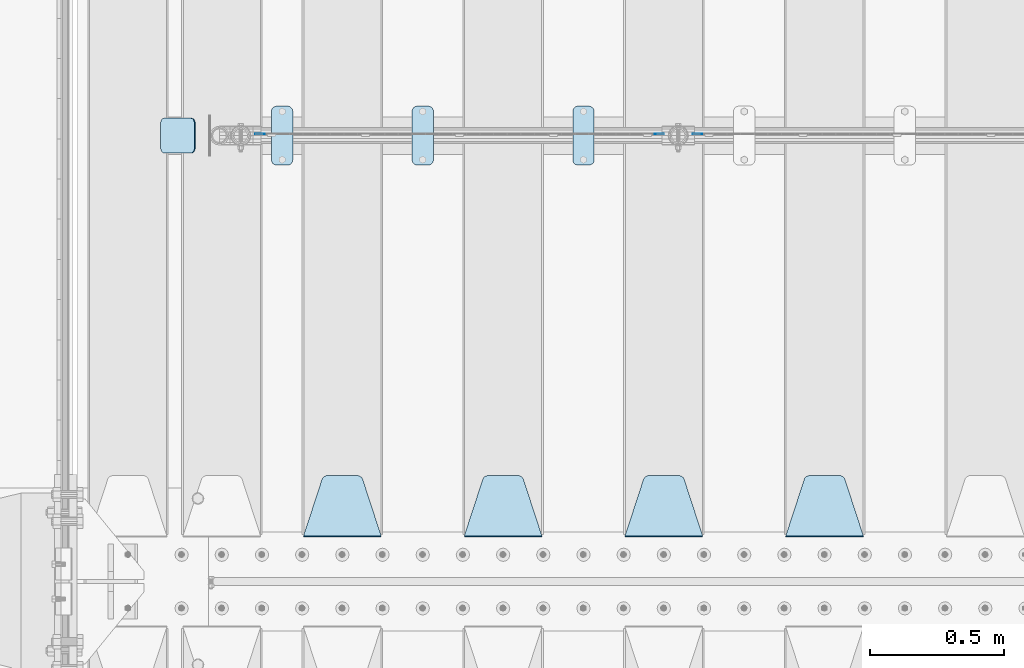
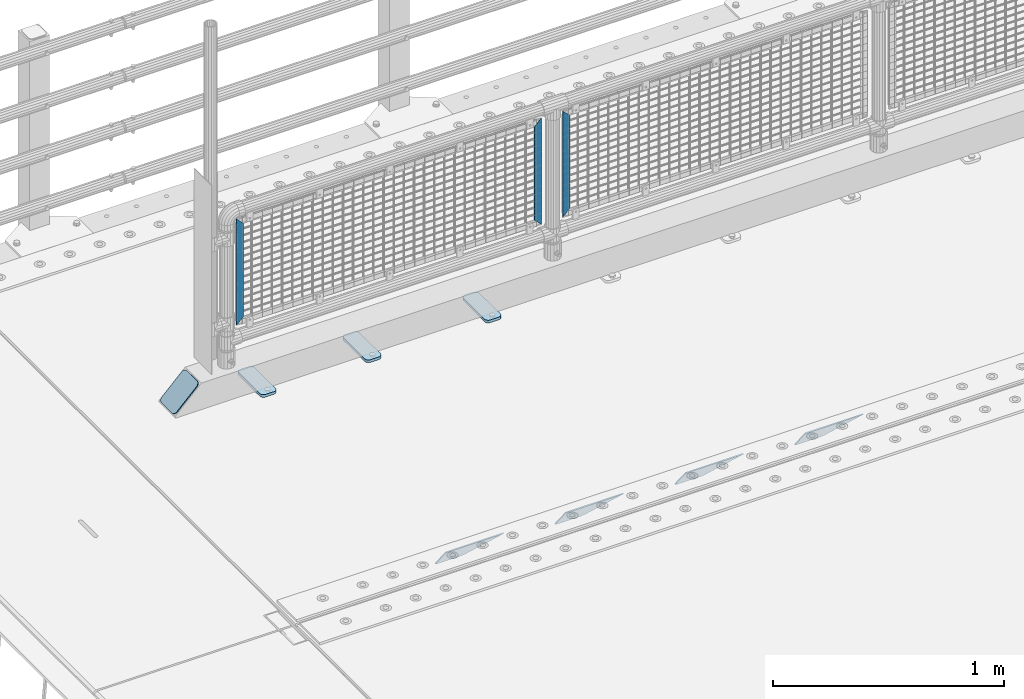
# One storey, part 199 of 242: 11 plates.
"""IFC2X3 building model written with IfcOpenShell, lengths in millimetres."""

from ifc_helpers import new_model, si_unit, frame, origin_with_axes, place, context, subcontext, project, spatial, faceted_brep, material, type_object, element, save


model = new_model("IFC2X3")

# Units and contexts
model_context = context("Model", 3, precision=1e-05, world=origin_with_axes())
body_context = subcontext(model_context, "Body", "Model", "MODEL_VIEW")
ifc_project = project(units=[si_unit("LENGTHUNIT", "METRE", prefix="MILLI"), si_unit("AREAUNIT", "SQUARE_METRE"), si_unit("VOLUMEUNIT", "CUBIC_METRE"), si_unit("MASSUNIT", "GRAM", prefix="KILO"), si_unit("TIMEUNIT", "SECOND"), si_unit("PLANEANGLEUNIT", "RADIAN"), si_unit("SOLIDANGLEUNIT", "STERADIAN"), si_unit("THERMODYNAMICTEMPERATUREUNIT", "DEGREE_CELSIUS"), si_unit("LUMINOUSINTENSITYUNIT", "LUMEN")], contexts=[model_context])

# Site, building, storey
site_placement = place(None, origin_with_axes())
site = spatial("IfcSite", under=ifc_project, at=site_placement, CompositionType="ELEMENT")
building_placement = place(site_placement, origin_with_axes())
building = spatial("IfcBuilding", under=site, at=building_placement, Name="Standard", CompositionType="ELEMENT")
storey_placement = place(building_placement, origin_with_axes())
storey = spatial("IfcBuildingStorey", under=building, at=storey_placement, Name="Undefined", CompositionType="ELEMENT", Elevation=0.0)

# Plates
ifc_material_1 = material(Name="Misc_Undefined")
plate_type_1 = type_object("IfcPlateType", PredefinedType="NOTDEFINED")
for number, where, z_axis, x_axis in (
    (1, (-40107.490286459, -19329.5, 879.519963133601), (-0.707008801899319, 0.0, -0.707204746899291), (-0.707204746899296, 0.0, 0.707008801899313)),
    (2, (-41740.490286459, -19329.5, 879.519963133601), (-0.707008801899319, 0.0, -0.707204746899291), (-0.707204746899296, 0.0, 0.707008801899313)),
):
    element("IfcPlate", number, at=place(storey_placement, frame(where, z_axis=z_axis, x_axis=x_axis)), inside=storey, type_object=plate_type_1, material=ifc_material_1, context=body_context, shape_type="Brep", body=[
        faceted_brep([(0.0, -1.50000000000364, 0.0), (-348.552185058597, -1.5, 348.655029296875), (-348.552185058597, 1.5, 348.655029296875), (-3.63797880709171e-12, 1.49999999999636, 0.0), (-348.544891357426, -1.5, 398.152496337891), (-348.544891357426, 1.5, 398.152496337891), (49.5043945312464, -1.5, 8.00355337560177e-11), (49.5043945312464, 1.5, 8.00355337560177e-11)], [[[0, 1, 2, 3]], [[1, 4, 5, 2]], [[4, 6, 7, 5]], [[6, 0, 3, 7]], [[5, 7, 3, 2]], [[6, 4, 1, 0]]]),
    ])
plate_1_placement = place(storey_placement, frame((-40284.5003125164, -19329.5, 879.52), z_axis=(0.707103624179499, 0.0, -0.707109938179501), x_axis=(0.707109938179508, 0.0, 0.707103624179492)))
element("IfcPlate", 3, at=plate_1_placement, inside=storey, type_object=plate_type_1, material=ifc_material_1, context=body_context, shape_type="Brep", body=[
    faceted_brep([(0.0, -1.50000000000364, 0.0), (-348.605163574222, -1.5, 348.602081298832), (-348.605163574222, 1.5, 348.602081298832), (-3.63797880709171e-12, 1.49999999999636, 0.0), (-348.605163574222, -1.5, 398.099334716801), (-348.605163574222, 1.5, 398.099334716801), (49.4976959228534, -1.5, -3.63797880709171e-12), (49.4976959228534, 1.5, -3.63797880709171e-12)], [[[0, 1, 2, 3]], [[1, 4, 5, 2]], [[4, 6, 7, 5]], [[6, 0, 3, 7]], [[5, 7, 3, 2]], [[6, 4, 1, 0]]]),
])
ifc_material_2 = material(Name="STEEL/S355J2")
plate_type_2 = type_object("IfcPlateType", PredefinedType="NOTDEFINED")
plate_2_placement = place(storey_placement, frame((-40590.0, -19225.5, 21.0199999999977), z_axis=(1.0, 0.0, 0.0), x_axis=(0.0, -1.0, 0.0)))
element("IfcPlate", 4, at=plate_2_placement, inside=storey, type_object=plate_type_2, material=ifc_material_2, context=body_context, shape_type="Brep", body=[
    faceted_brep([(0.0, -7.0, 20.0), (0.0, -7.0, 60.0), (0.0, 7.0, 60.0), (0.0, 7.0, 20.0), (0.384294391937146, -7.0, 63.9018064403208), (0.384294391937146, 7.0, 63.9018064403208), (1.52240934977453, -7.0, 67.6536686473009), (1.52240934977453, 7.0, 67.6536686473009), (3.37060775395003, -7.0, 71.1114046603907), (3.37060775395003, 7.0, 71.1114046603907), (5.8578643762703, -7.0, 74.1421356237297), (5.8578643762703, 7.0, 74.1421356237297), (8.88859533960931, -7.0, 76.62939224605), (8.88859533960931, 7.0, 76.62939224605), (12.3463313526991, -7.0, 78.4775906502255), (12.3463313526991, 7.0, 78.4775906502255), (16.0981935596792, -7.0, 79.6157056080629), (16.0981935596792, 7.0, 79.6157056080629), (20.0, -7.0, 80.0), (20.0, 7.0, 80.0), (200.0, -7.0, 80.0), (200.0, 7.0, 80.0), (203.901806440321, -7.0, 79.6157056080629), (203.901806440321, 7.0, 79.6157056080629), (207.653668647301, -7.0, 78.4775906502255), (207.653668647301, 7.0, 78.4775906502255), (211.111404660391, -7.0, 76.62939224605), (211.111404660391, 7.0, 76.62939224605), (214.14213562373, -7.0, 74.1421356237297), (214.14213562373, 7.0, 74.1421356237297), (216.62939224605, -7.0, 71.1114046603907), (216.62939224605, 7.0, 71.1114046603907), (218.477590650225, -7.0, 67.6536686473009), (218.477590650225, 7.0, 67.6536686473009), (219.615705608063, -7.0, 63.9018064403208), (219.615705608063, 7.0, 63.9018064403208), (220.0, -7.0, 60.0), (220.0, 7.0, 60.0), (220.0, -7.0, 20.0), (220.0, 7.0, 20.0), (219.615705608063, -7.0, 16.0981935596792), (219.615705608063, 7.0, 16.0981935596792), (218.477590650225, -7.0, 12.3463313526991), (218.477590650225, 7.0, 12.3463313526991), (216.62939224605, -7.0, 8.88859533960931), (216.62939224605, 7.0, 8.88859533960931), (214.14213562373, -7.0, 5.8578643762703), (214.14213562373, 7.0, 5.8578643762703), (211.111404660391, -7.0, 3.37060775395003), (211.111404660391, 7.0, 3.37060775395003), (207.653668647301, -7.0, 1.52240934977453), (207.653668647301, 7.0, 1.52240934977453), (203.901806440321, -7.0, 0.384294391937146), (203.901806440321, 7.0, 0.384294391937146), (200.0, -7.0, 0.0), (200.0, 7.0, 0.0), (20.0, -7.0, 0.0), (20.0, 7.0, 0.0), (16.0981935596792, -7.0, 0.384294391937146), (16.0981935596792, 7.0, 0.384294391937146), (12.3463313526991, -7.0, 1.52240934977453), (12.3463313526991, 7.0, 1.52240934977453), (8.88859533960931, -7.0, 3.37060775395003), (8.88859533960931, 7.0, 3.37060775395003), (5.8578643762703, -7.0, 5.8578643762703), (5.8578643762703, 7.0, 5.8578643762703), (3.37060775395003, -7.0, 8.88859533960931), (3.37060775395003, 7.0, 8.88859533960931), (1.52240934977453, -7.0, 12.3463313526991), (1.52240934977453, 7.0, 12.3463313526991), (0.384294391937146, -7.0, 16.0981935596792), (0.384294391937146, 7.0, 16.0981935596792)], [[[0, 1, 2, 3]], [[1, 4, 5, 2]], [[4, 6, 7, 5]], [[6, 8, 9, 7]], [[8, 10, 11, 9]], [[10, 12, 13, 11]], [[12, 14, 15, 13]], [[14, 16, 17, 15]], [[16, 18, 19, 17]], [[18, 20, 21, 19]], [[20, 22, 23, 21]], [[22, 24, 25, 23]], [[24, 26, 27, 25]], [[26, 28, 29, 27]], [[28, 30, 31, 29]], [[30, 32, 33, 31]], [[32, 34, 35, 33]], [[34, 36, 37, 35]], [[36, 38, 39, 37]], [[38, 40, 41, 39]], [[40, 42, 43, 41]], [[42, 44, 45, 43]], [[44, 46, 47, 45]], [[46, 48, 49, 47]], [[48, 50, 51, 49]], [[50, 52, 53, 51]], [[52, 54, 55, 53]], [[54, 56, 57, 55]], [[56, 58, 59, 57]], [[58, 60, 61, 59]], [[60, 62, 63, 61]], [[62, 64, 65, 63]], [[64, 66, 67, 65]], [[66, 68, 69, 67]], [[68, 70, 71, 69]], [[70, 0, 3, 71]], [[5, 7, 9, 11, 13, 15, 17, 19, 21, 23, 25, 27, 29, 31, 33, 35, 37, 39, 41, 43, 45, 47, 49, 51, 53, 55, 57, 59, 61, 63, 65, 67, 69, 71, 3, 2]], [[70, 68, 66, 64, 62, 60, 58, 56, 54, 52, 50, 48, 46, 44, 42, 40, 38, 36, 34, 32, 30, 28, 26, 24, 22, 20, 18, 16, 14, 12, 10, 8, 6, 4, 1, 0]]]),
])
plate_3_placement = place(storey_placement, frame((-41190.0, -19225.5, 21.0199999999977), z_axis=(1.0, 0.0, 0.0), x_axis=(0.0, -1.0, 0.0)))
element("IfcPlate", 5, at=plate_3_placement, inside=storey, type_object=plate_type_2, material=ifc_material_2, context=body_context, shape_type="Brep", body=[
    faceted_brep([(0.0, -7.0, 20.0), (0.0, -7.0, 60.0), (0.0, 7.0, 60.0), (0.0, 7.0, 20.0), (0.384294391937146, -7.0, 63.9018064403208), (0.384294391937146, 7.0, 63.9018064403208), (1.52240934977453, -7.0, 67.6536686473009), (1.52240934977453, 7.0, 67.6536686473009), (3.37060775395003, -7.0, 71.1114046603907), (3.37060775395003, 7.0, 71.1114046603907), (5.8578643762703, -7.0, 74.1421356237297), (5.8578643762703, 7.0, 74.1421356237297), (8.88859533960931, -7.0, 76.62939224605), (8.88859533960931, 7.0, 76.62939224605), (12.3463313526991, -7.0, 78.4775906502255), (12.3463313526991, 7.0, 78.4775906502255), (16.0981935596792, -7.0, 79.6157056080629), (16.0981935596792, 7.0, 79.6157056080629), (20.0, -7.0, 80.0), (20.0, 7.0, 80.0), (200.0, -7.0, 80.0), (200.0, 7.0, 80.0), (203.901806440321, -7.0, 79.6157056080629), (203.901806440321, 7.0, 79.6157056080629), (207.653668647301, -7.0, 78.4775906502255), (207.653668647301, 7.0, 78.4775906502255), (211.111404660391, -7.0, 76.62939224605), (211.111404660391, 7.0, 76.62939224605), (214.14213562373, -7.0, 74.1421356237297), (214.14213562373, 7.0, 74.1421356237297), (216.62939224605, -7.0, 71.1114046603907), (216.62939224605, 7.0, 71.1114046603907), (218.477590650225, -7.0, 67.6536686473009), (218.477590650225, 7.0, 67.6536686473009), (219.615705608063, -7.0, 63.9018064403208), (219.615705608063, 7.0, 63.9018064403208), (220.0, -7.0, 60.0), (220.0, 7.0, 60.0), (220.0, -7.0, 20.0), (220.0, 7.0, 20.0), (219.615705608063, -7.0, 16.0981935596792), (219.615705608063, 7.0, 16.0981935596792), (218.477590650225, -7.0, 12.3463313526991), (218.477590650225, 7.0, 12.3463313526991), (216.62939224605, -7.0, 8.88859533960931), (216.62939224605, 7.0, 8.88859533960931), (214.14213562373, -7.0, 5.8578643762703), (214.14213562373, 7.0, 5.8578643762703), (211.111404660391, -7.0, 3.37060775395003), (211.111404660391, 7.0, 3.37060775395003), (207.653668647301, -7.0, 1.52240934977453), (207.653668647301, 7.0, 1.52240934977453), (203.901806440321, -7.0, 0.384294391937146), (203.901806440321, 7.0, 0.384294391937146), (200.0, -7.0, 0.0), (200.0, 7.0, 0.0), (20.0, -7.0, 0.0), (20.0, 7.0, 0.0), (16.0981935596792, -7.0, 0.384294391937146), (16.0981935596792, 7.0, 0.384294391937146), (12.3463313526991, -7.0, 1.52240934977453), (12.3463313526991, 7.0, 1.52240934977453), (8.88859533960931, -7.0, 3.37060775395003), (8.88859533960931, 7.0, 3.37060775395003), (5.8578643762703, -7.0, 5.8578643762703), (5.8578643762703, 7.0, 5.8578643762703), (3.37060775395003, -7.0, 8.88859533960931), (3.37060775395003, 7.0, 8.88859533960931), (1.52240934977453, -7.0, 12.3463313526991), (1.52240934977453, 7.0, 12.3463313526991), (0.384294391937146, -7.0, 16.0981935596792), (0.384294391937146, 7.0, 16.0981935596792)], [[[0, 1, 2, 3]], [[1, 4, 5, 2]], [[4, 6, 7, 5]], [[6, 8, 9, 7]], [[8, 10, 11, 9]], [[10, 12, 13, 11]], [[12, 14, 15, 13]], [[14, 16, 17, 15]], [[16, 18, 19, 17]], [[18, 20, 21, 19]], [[20, 22, 23, 21]], [[22, 24, 25, 23]], [[24, 26, 27, 25]], [[26, 28, 29, 27]], [[28, 30, 31, 29]], [[30, 32, 33, 31]], [[32, 34, 35, 33]], [[34, 36, 37, 35]], [[36, 38, 39, 37]], [[38, 40, 41, 39]], [[40, 42, 43, 41]], [[42, 44, 45, 43]], [[44, 46, 47, 45]], [[46, 48, 49, 47]], [[48, 50, 51, 49]], [[50, 52, 53, 51]], [[52, 54, 55, 53]], [[54, 56, 57, 55]], [[56, 58, 59, 57]], [[58, 60, 61, 59]], [[60, 62, 63, 61]], [[62, 64, 65, 63]], [[64, 66, 67, 65]], [[66, 68, 69, 67]], [[68, 70, 71, 69]], [[70, 0, 3, 71]], [[5, 7, 9, 11, 13, 15, 17, 19, 21, 23, 25, 27, 29, 31, 33, 35, 37, 39, 41, 43, 45, 47, 49, 51, 53, 55, 57, 59, 61, 63, 65, 67, 69, 71, 3, 2]], [[70, 68, 66, 64, 62, 60, 58, 56, 54, 52, 50, 48, 46, 44, 42, 40, 38, 36, 34, 32, 30, 28, 26, 24, 22, 20, 18, 16, 14, 12, 10, 8, 6, 4, 1, 0]]]),
])
plate_4_placement = place(storey_placement, frame((-41715.0, -19225.5, 21.0199999999977), z_axis=(1.0, 0.0, 0.0), x_axis=(0.0, -1.0, 0.0)))
element("IfcPlate", 6, at=plate_4_placement, inside=storey, type_object=plate_type_2, material=ifc_material_2, context=body_context, shape_type="Brep", body=[
    faceted_brep([(0.0, -7.0, 20.0), (0.0, -7.0, 60.0), (0.0, 7.0, 60.0), (0.0, 7.0, 20.0), (0.384294391937146, -7.0, 63.9018064403208), (0.384294391937146, 7.0, 63.9018064403208), (1.52240934977453, -7.0, 67.6536686473009), (1.52240934977453, 7.0, 67.6536686473009), (3.37060775395003, -7.0, 71.1114046603907), (3.37060775395003, 7.0, 71.1114046603907), (5.8578643762703, -7.0, 74.1421356237297), (5.8578643762703, 7.0, 74.1421356237297), (8.88859533960931, -7.0, 76.62939224605), (8.88859533960931, 7.0, 76.62939224605), (12.3463313526991, -7.0, 78.4775906502255), (12.3463313526991, 7.0, 78.4775906502255), (16.0981935596792, -7.0, 79.6157056080629), (16.0981935596792, 7.0, 79.6157056080629), (20.0, -7.0, 80.0), (20.0, 7.0, 80.0), (200.0, -7.0, 80.0), (200.0, 7.0, 80.0), (203.901806440321, -7.0, 79.6157056080629), (203.901806440321, 7.0, 79.6157056080629), (207.653668647301, -7.0, 78.4775906502255), (207.653668647301, 7.0, 78.4775906502255), (211.111404660391, -7.0, 76.62939224605), (211.111404660391, 7.0, 76.62939224605), (214.14213562373, -7.0, 74.1421356237297), (214.14213562373, 7.0, 74.1421356237297), (216.62939224605, -7.0, 71.1114046603907), (216.62939224605, 7.0, 71.1114046603907), (218.477590650225, -7.0, 67.6536686473009), (218.477590650225, 7.0, 67.6536686473009), (219.615705608063, -7.0, 63.9018064403208), (219.615705608063, 7.0, 63.9018064403208), (220.0, -7.0, 60.0), (220.0, 7.0, 60.0), (220.0, -7.0, 20.0), (220.0, 7.0, 20.0), (219.615705608063, -7.0, 16.0981935596792), (219.615705608063, 7.0, 16.0981935596792), (218.477590650225, -7.0, 12.3463313526991), (218.477590650225, 7.0, 12.3463313526991), (216.62939224605, -7.0, 8.88859533960931), (216.62939224605, 7.0, 8.88859533960931), (214.14213562373, -7.0, 5.8578643762703), (214.14213562373, 7.0, 5.8578643762703), (211.111404660391, -7.0, 3.37060775395003), (211.111404660391, 7.0, 3.37060775395003), (207.653668647301, -7.0, 1.52240934977453), (207.653668647301, 7.0, 1.52240934977453), (203.901806440321, -7.0, 0.384294391937146), (203.901806440321, 7.0, 0.384294391937146), (200.0, -7.0, 0.0), (200.0, 7.0, 0.0), (20.0, -7.0, 0.0), (20.0, 7.0, 0.0), (16.0981935596792, -7.0, 0.384294391937146), (16.0981935596792, 7.0, 0.384294391937146), (12.3463313526991, -7.0, 1.52240934977453), (12.3463313526991, 7.0, 1.52240934977453), (8.88859533960931, -7.0, 3.37060775395003), (8.88859533960931, 7.0, 3.37060775395003), (5.8578643762703, -7.0, 5.8578643762703), (5.8578643762703, 7.0, 5.8578643762703), (3.37060775395003, -7.0, 8.88859533960931), (3.37060775395003, 7.0, 8.88859533960931), (1.52240934977453, -7.0, 12.3463313526991), (1.52240934977453, 7.0, 12.3463313526991), (0.384294391937146, -7.0, 16.0981935596792), (0.384294391937146, 7.0, 16.0981935596792)], [[[0, 1, 2, 3]], [[1, 4, 5, 2]], [[4, 6, 7, 5]], [[6, 8, 9, 7]], [[8, 10, 11, 9]], [[10, 12, 13, 11]], [[12, 14, 15, 13]], [[14, 16, 17, 15]], [[16, 18, 19, 17]], [[18, 20, 21, 19]], [[20, 22, 23, 21]], [[22, 24, 25, 23]], [[24, 26, 27, 25]], [[26, 28, 29, 27]], [[28, 30, 31, 29]], [[30, 32, 33, 31]], [[32, 34, 35, 33]], [[34, 36, 37, 35]], [[36, 38, 39, 37]], [[38, 40, 41, 39]], [[40, 42, 43, 41]], [[42, 44, 45, 43]], [[44, 46, 47, 45]], [[46, 48, 49, 47]], [[48, 50, 51, 49]], [[50, 52, 53, 51]], [[52, 54, 55, 53]], [[54, 56, 57, 55]], [[56, 58, 59, 57]], [[58, 60, 61, 59]], [[60, 62, 63, 61]], [[62, 64, 65, 63]], [[64, 66, 67, 65]], [[66, 68, 69, 67]], [[68, 70, 71, 69]], [[70, 0, 3, 71]], [[5, 7, 9, 11, 13, 15, 17, 19, 21, 23, 25, 27, 29, 31, 33, 35, 37, 39, 41, 43, 45, 47, 49, 51, 53, 55, 57, 59, 61, 63, 65, 67, 69, 71, 3, 2]], [[70, 68, 66, 64, 62, 60, 58, 56, 54, 52, 50, 48, 46, 44, 42, 40, 38, 36, 34, 32, 30, 28, 26, 24, 22, 20, 18, 16, 14, 12, 10, 8, 6, 4, 1, 0]]]),
])
plate_type_3 = type_object("IfcPlateType", PredefinedType="NOTDEFINED")
plate_5_placement = place(storey_placement, frame((-42000.192418479, -19270.5, 166.254400376568), z_axis=(-0.707410512925779, 0.0, -0.70680291892584), x_axis=(0.0, -1.0, 0.0)))
element("IfcPlate", 7, at=plate_5_placement, inside=storey, type_object=plate_type_3, material=ifc_material_2, context=body_context, shape_type="Brep", body=[
    faceted_brep([(0.0, -2.49999999999636, 20.0), (0.0, -2.49999999999636, 158.926651000977), (0.0, 2.50000000000364, 158.926651000977), (0.0, 2.50000000000364, 20.0), (0.384294391937146, -2.49999999999636, 162.828457441301), (0.384294391937146, 2.50000000000364, 162.828457441301), (1.52240934977453, -2.49999999999636, 166.580319648281), (1.52240934977453, 2.50000000000364, 166.580319648281), (3.37060775395003, -2.49999999999636, 170.038055661371), (3.37060775395003, 2.50000000000364, 170.038055661371), (5.8578643762703, -2.49999999999636, 173.068786624706), (5.8578643762703, 2.50000000000364, 173.06878662471), (8.88859533960931, -2.5, 175.55604324703), (8.88859533960931, 2.50000000000364, 175.55604324703), (12.3463313526991, -2.49999999999636, 177.404241651206), (12.3463313526991, 2.50000000000364, 177.404241651206), (16.0981935596792, -2.49999999999636, 178.542356609043), (16.0981935596792, 2.50000000000728, 178.542356609043), (20.0, -2.49999999999272, 178.926651000977), (20.0, 2.50000000000364, 178.92665100098), (110.0, -2.49999999999272, 178.926651000977), (110.0, 2.50000000000364, 178.92665100098), (113.901806440321, -2.49999999999636, 178.542356609043), (113.901806440321, 2.50000000000728, 178.542356609043), (117.653668647301, -2.49999999999636, 177.404241651206), (117.653668647301, 2.50000000000364, 177.404241651206), (121.111404660391, -2.5, 175.55604324703), (121.111404660391, 2.50000000000364, 175.55604324703), (124.14213562373, -2.49999999999636, 173.068786624706), (124.14213562373, 2.50000000000364, 173.06878662471), (126.62939224605, -2.49999999999636, 170.038055661371), (126.62939224605, 2.50000000000364, 170.038055661371), (128.477590650225, -2.49999999999636, 166.580319648281), (128.477590650225, 2.50000000000364, 166.580319648281), (129.615705608063, -2.49999999999636, 162.828457441301), (129.615705608063, 2.50000000000364, 162.828457441301), (130.0, -2.49999999999636, 158.926651000977), (130.0, 2.50000000000364, 158.926651000977), (130.0, -2.49999999999636, 20.0), (130.0, 2.50000000000364, 20.0), (129.615705608063, -2.49999999999636, 16.0981935596792), (129.615705608063, 2.50000000000364, 16.0981935596792), (128.477590650225, -2.49999999999636, 12.3463313526991), (128.477590650225, 2.50000000000364, 12.3463313526991), (126.62939224605, -2.49999999999636, 8.88859533961295), (126.62939224605, 2.5, 8.88859533960931), (124.14213562373, -2.49999999999636, 5.8578643762703), (124.14213562373, 2.5, 5.8578643762703), (121.111404660391, -2.49999999999636, 3.37060775395003), (121.111404660391, 2.50000000000364, 3.37060775395003), (117.653668647301, -2.49999999999636, 1.52240934977453), (117.653668647301, 2.50000000000364, 1.52240934977453), (113.901806440321, -2.49999999999636, 0.384294391933508), (113.901806440321, 2.50000000000364, 0.384294391937146), (110.0, -2.49999999999636, 3.63797880709171e-12), (110.0, 2.50000000000728, 3.63797880709171e-12), (20.0, -2.49999999999636, 3.63797880709171e-12), (20.0, 2.50000000000728, 3.63797880709171e-12), (16.0981935596792, -2.49999999999636, 0.384294391933508), (16.0981935596792, 2.50000000000364, 0.384294391937146), (12.3463313526991, -2.49999999999636, 1.52240934977453), (12.3463313526991, 2.50000000000364, 1.52240934977453), (8.88859533960931, -2.49999999999636, 3.37060775395003), (8.88859533960931, 2.50000000000364, 3.37060775395003), (5.8578643762703, -2.49999999999636, 5.8578643762703), (5.8578643762703, 2.5, 5.8578643762703), (3.37060775395003, -2.49999999999636, 8.88859533961295), (3.37060775395003, 2.5, 8.88859533960931), (1.52240934977453, -2.49999999999636, 12.3463313526991), (1.52240934977453, 2.50000000000364, 12.3463313526991), (0.384294391937146, -2.49999999999636, 16.0981935596792), (0.384294391937146, 2.50000000000364, 16.0981935596792)], [[[0, 1, 2, 3]], [[1, 4, 5, 2]], [[4, 6, 7, 5]], [[6, 8, 9, 7]], [[8, 10, 11, 9]], [[10, 12, 13, 11]], [[12, 14, 15, 13]], [[14, 16, 17, 15]], [[16, 18, 19, 17]], [[18, 20, 21, 19]], [[20, 22, 23, 21]], [[22, 24, 25, 23]], [[24, 26, 27, 25]], [[26, 28, 29, 27]], [[28, 30, 31, 29]], [[30, 32, 33, 31]], [[32, 34, 35, 33]], [[34, 36, 37, 35]], [[36, 38, 39, 37]], [[38, 40, 41, 39]], [[40, 42, 43, 41]], [[42, 44, 45, 43]], [[44, 46, 47, 45]], [[46, 48, 49, 47]], [[48, 50, 51, 49]], [[50, 52, 53, 51]], [[52, 54, 55, 53]], [[54, 56, 57, 55]], [[56, 58, 59, 57]], [[58, 60, 61, 59]], [[60, 62, 63, 61]], [[62, 64, 65, 63]], [[64, 66, 67, 65]], [[66, 68, 69, 67]], [[68, 70, 71, 69]], [[70, 0, 3, 71]], [[5, 7, 9, 11, 13, 15, 17, 19, 21, 23, 25, 27, 29, 31, 33, 35, 37, 39, 41, 43, 45, 47, 49, 51, 53, 55, 57, 59, 61, 63, 65, 67, 69, 71, 3, 2]], [[70, 68, 66, 64, 62, 60, 58, 56, 54, 52, 50, 48, 46, 44, 42, 40, 38, 36, 34, 32, 30, 28, 26, 24, 22, 20, 18, 16, 14, 12, 10, 8, 6, 4, 1, 0]]]),
])
ifc_material_3 = material(Name="STEEL/S355N")
plate_type_4 = type_object("IfcPlateType", PredefinedType="NOTDEFINED")
plate_6_placement = place(storey_placement, frame((-39505.0, -20831.767766953, -1.76776695296758), z_axis=(0.0, 0.707106781186547, -0.707106781186548), x_axis=(-1.0, 0.0, 0.0)))
element("IfcPlate", 8, at=plate_6_placement, inside=storey, type_object=plate_type_4, material=ifc_material_3, context=body_context, shape_type="Brep", body=[
    faceted_brep([(0.0, -2.5, 0.0), (69.345504679477, -2.50000000000182, 300.171731424829), (69.345504679477, 2.5, 300.171731424829), (0.0, 2.5, 0.0), (70.9274061199576, -2.5, 304.897442415398), (70.9274061199576, 2.5, 304.897442415398), (73.3818627772307, -2.5, 309.234538108525), (73.3818627772307, 2.50000000000182, 309.234538108529), (76.6187032999551, -2.5, 313.023683126101), (76.6187032999551, 2.50000000000182, 313.023683126103), (80.5190132704993, -2.5, 316.12567259537), (80.5190132704993, 2.5, 316.12567259537), (84.9395038596849, -2.5, 318.426546230474), (84.9395038596849, 2.50000000000182, 318.426546230476), (89.7177759439219, -2.49999999999818, 319.841774983273), (89.7177759439219, 2.50000000000182, 319.841774983273), (94.678286292652, -2.5, 320.319366455076), (94.678286292652, 2.5, 320.319366455076), (195.321713707348, -2.5, 320.319366455076), (195.321713707348, 2.5, 320.319366455076), (200.282224056078, -2.5, 319.841774983272), (200.282224056078, 2.50000000000182, 319.841774983273), (205.060496140315, -2.5, 318.426546230474), (205.060496140315, 2.49999999999818, 318.426546230474), (209.480986729501, -2.49999999999818, 316.12567259537), (209.480986729501, 2.5, 316.12567259537), (213.381296700045, -2.5, 313.023683126101), (213.381296700045, 2.49999999999818, 313.023683126101), (216.618137222769, -2.5, 309.234538108525), (216.618137222769, 2.5, 309.234538108523), (219.072593880042, -2.49999999999818, 304.897442415398), (219.072593880042, 2.50000000000182, 304.897442415398), (220.654495320523, -2.50000000000182, 300.171731424829), (220.654495320523, 2.5, 300.171731424829), (290.0, -2.5, 0.0), (290.0, 2.5, -1.81898940354586e-12)], [[[0, 1, 2, 3]], [[1, 4, 5, 2]], [[4, 6, 7, 5]], [[6, 8, 9, 7]], [[8, 10, 11, 9]], [[10, 12, 13, 11]], [[12, 14, 15, 13]], [[14, 16, 17, 15]], [[16, 18, 19, 17]], [[18, 20, 21, 19]], [[20, 22, 23, 21]], [[22, 24, 25, 23]], [[24, 26, 27, 25]], [[26, 28, 29, 27]], [[28, 30, 31, 29]], [[30, 32, 33, 31]], [[32, 34, 35, 33]], [[34, 0, 3, 35]], [[5, 7, 9, 11, 13, 15, 17, 19, 21, 23, 25, 27, 29, 31, 33, 35, 3, 2]], [[34, 32, 30, 28, 26, 24, 22, 20, 18, 16, 14, 12, 10, 8, 6, 4, 1, 0]]]),
])
plate_7_placement = place(storey_placement, frame((-40105.0, -20831.767766953, -1.76776695296758), z_axis=(0.0, 0.707106781186547, -0.707106781186548), x_axis=(-1.0, 0.0, 0.0)))
element("IfcPlate", 9, at=plate_7_placement, inside=storey, type_object=plate_type_4, material=ifc_material_3, context=body_context, shape_type="Brep", body=[
    faceted_brep([(0.0, -2.5, 0.0), (69.345504679477, -2.50000000000182, 300.171731424829), (69.345504679477, 2.5, 300.171731424829), (0.0, 2.5, 0.0), (70.9274061199576, -2.5, 304.897442415398), (70.9274061199576, 2.5, 304.897442415398), (73.3818627772307, -2.5, 309.234538108525), (73.3818627772307, 2.50000000000182, 309.234538108529), (76.6187032999551, -2.5, 313.023683126101), (76.6187032999551, 2.50000000000182, 313.023683126103), (80.5190132704993, -2.5, 316.12567259537), (80.5190132704993, 2.5, 316.12567259537), (84.9395038596849, -2.5, 318.426546230474), (84.9395038596849, 2.50000000000182, 318.426546230476), (89.7177759439219, -2.49999999999818, 319.841774983273), (89.7177759439219, 2.50000000000182, 319.841774983273), (94.678286292652, -2.5, 320.319366455076), (94.678286292652, 2.5, 320.319366455076), (195.321713707348, -2.5, 320.319366455076), (195.321713707348, 2.5, 320.319366455076), (200.282224056078, -2.5, 319.841774983272), (200.282224056078, 2.50000000000182, 319.841774983273), (205.060496140315, -2.5, 318.426546230474), (205.060496140315, 2.49999999999818, 318.426546230474), (209.480986729501, -2.49999999999818, 316.12567259537), (209.480986729501, 2.5, 316.12567259537), (213.381296700045, -2.5, 313.023683126101), (213.381296700045, 2.49999999999818, 313.023683126101), (216.618137222769, -2.5, 309.234538108525), (216.618137222769, 2.5, 309.234538108523), (219.072593880042, -2.49999999999818, 304.897442415398), (219.072593880042, 2.50000000000182, 304.897442415398), (220.654495320523, -2.50000000000182, 300.171731424829), (220.654495320523, 2.5, 300.171731424829), (290.0, -2.5, 0.0), (290.0, 2.5, -1.81898940354586e-12)], [[[0, 1, 2, 3]], [[1, 4, 5, 2]], [[4, 6, 7, 5]], [[6, 8, 9, 7]], [[8, 10, 11, 9]], [[10, 12, 13, 11]], [[12, 14, 15, 13]], [[14, 16, 17, 15]], [[16, 18, 19, 17]], [[18, 20, 21, 19]], [[20, 22, 23, 21]], [[22, 24, 25, 23]], [[24, 26, 27, 25]], [[26, 28, 29, 27]], [[28, 30, 31, 29]], [[30, 32, 33, 31]], [[32, 34, 35, 33]], [[34, 0, 3, 35]], [[5, 7, 9, 11, 13, 15, 17, 19, 21, 23, 25, 27, 29, 31, 33, 35, 3, 2]], [[34, 32, 30, 28, 26, 24, 22, 20, 18, 16, 14, 12, 10, 8, 6, 4, 1, 0]]]),
])
plate_8_placement = place(storey_placement, frame((-40705.0, -20831.767766953, -1.76776695296758), z_axis=(0.0, 0.707106781186547, -0.707106781186548), x_axis=(-1.0, 0.0, 0.0)))
element("IfcPlate", 10, at=plate_8_placement, inside=storey, type_object=plate_type_4, material=ifc_material_3, context=body_context, shape_type="Brep", body=[
    faceted_brep([(0.0, -2.5, 0.0), (69.345504679477, -2.50000000000182, 300.171731424829), (69.345504679477, 2.5, 300.171731424829), (0.0, 2.5, 0.0), (70.9274061199576, -2.5, 304.897442415398), (70.9274061199576, 2.5, 304.897442415398), (73.3818627772307, -2.5, 309.234538108525), (73.3818627772307, 2.50000000000182, 309.234538108529), (76.6187032999551, -2.5, 313.023683126101), (76.6187032999551, 2.50000000000182, 313.023683126103), (80.5190132704993, -2.5, 316.12567259537), (80.5190132704993, 2.5, 316.12567259537), (84.9395038596849, -2.5, 318.426546230474), (84.9395038596849, 2.50000000000182, 318.426546230476), (89.7177759439219, -2.49999999999818, 319.841774983273), (89.7177759439219, 2.50000000000182, 319.841774983273), (94.678286292652, -2.5, 320.319366455076), (94.678286292652, 2.5, 320.319366455076), (195.321713707348, -2.5, 320.319366455076), (195.321713707348, 2.5, 320.319366455076), (200.282224056078, -2.5, 319.841774983272), (200.282224056078, 2.50000000000182, 319.841774983273), (205.060496140315, -2.5, 318.426546230474), (205.060496140315, 2.49999999999818, 318.426546230474), (209.480986729501, -2.49999999999818, 316.12567259537), (209.480986729501, 2.5, 316.12567259537), (213.381296700045, -2.5, 313.023683126101), (213.381296700045, 2.49999999999818, 313.023683126101), (216.618137222769, -2.5, 309.234538108525), (216.618137222769, 2.5, 309.234538108523), (219.072593880042, -2.49999999999818, 304.897442415398), (219.072593880042, 2.50000000000182, 304.897442415398), (220.654495320523, -2.50000000000182, 300.171731424829), (220.654495320523, 2.5, 300.171731424829), (290.0, -2.5, 0.0), (290.0, 2.5, -1.81898940354586e-12)], [[[0, 1, 2, 3]], [[1, 4, 5, 2]], [[4, 6, 7, 5]], [[6, 8, 9, 7]], [[8, 10, 11, 9]], [[10, 12, 13, 11]], [[12, 14, 15, 13]], [[14, 16, 17, 15]], [[16, 18, 19, 17]], [[18, 20, 21, 19]], [[20, 22, 23, 21]], [[22, 24, 25, 23]], [[24, 26, 27, 25]], [[26, 28, 29, 27]], [[28, 30, 31, 29]], [[30, 32, 33, 31]], [[32, 34, 35, 33]], [[34, 0, 3, 35]], [[5, 7, 9, 11, 13, 15, 17, 19, 21, 23, 25, 27, 29, 31, 33, 35, 3, 2]], [[34, 32, 30, 28, 26, 24, 22, 20, 18, 16, 14, 12, 10, 8, 6, 4, 1, 0]]]),
])
plate_9_placement = place(storey_placement, frame((-41305.0, -20831.767766953, -1.76776695296758), z_axis=(0.0, 0.707106781186547, -0.707106781186548), x_axis=(-1.0, 0.0, 0.0)))
element("IfcPlate", 11, at=plate_9_placement, inside=storey, type_object=plate_type_4, material=ifc_material_3, context=body_context, shape_type="Brep", body=[
    faceted_brep([(0.0, -2.5, 0.0), (69.345504679477, -2.50000000000182, 300.171731424829), (69.345504679477, 2.5, 300.171731424829), (0.0, 2.5, 0.0), (70.9274061199576, -2.5, 304.897442415398), (70.9274061199576, 2.5, 304.897442415398), (73.3818627772307, -2.5, 309.234538108525), (73.3818627772307, 2.50000000000182, 309.234538108529), (76.6187032999551, -2.5, 313.023683126101), (76.6187032999551, 2.50000000000182, 313.023683126103), (80.5190132704993, -2.5, 316.12567259537), (80.5190132704993, 2.5, 316.12567259537), (84.9395038596849, -2.5, 318.426546230474), (84.9395038596849, 2.50000000000182, 318.426546230476), (89.7177759439219, -2.49999999999818, 319.841774983273), (89.7177759439219, 2.50000000000182, 319.841774983273), (94.678286292652, -2.5, 320.319366455076), (94.678286292652, 2.5, 320.319366455076), (195.321713707348, -2.5, 320.319366455076), (195.321713707348, 2.5, 320.319366455076), (200.282224056078, -2.5, 319.841774983272), (200.282224056078, 2.50000000000182, 319.841774983273), (205.060496140315, -2.5, 318.426546230474), (205.060496140315, 2.49999999999818, 318.426546230474), (209.480986729501, -2.49999999999818, 316.12567259537), (209.480986729501, 2.5, 316.12567259537), (213.381296700045, -2.5, 313.023683126101), (213.381296700045, 2.49999999999818, 313.023683126101), (216.618137222769, -2.5, 309.234538108525), (216.618137222769, 2.5, 309.234538108523), (219.072593880042, -2.49999999999818, 304.897442415398), (219.072593880042, 2.50000000000182, 304.897442415398), (220.654495320523, -2.50000000000182, 300.171731424829), (220.654495320523, 2.5, 300.171731424829), (290.0, -2.5, 0.0), (290.0, 2.5, -1.81898940354586e-12)], [[[0, 1, 2, 3]], [[1, 4, 5, 2]], [[4, 6, 7, 5]], [[6, 8, 9, 7]], [[8, 10, 11, 9]], [[10, 12, 13, 11]], [[12, 14, 15, 13]], [[14, 16, 17, 15]], [[16, 18, 19, 17]], [[18, 20, 21, 19]], [[20, 22, 23, 21]], [[22, 24, 25, 23]], [[24, 26, 27, 25]], [[26, 28, 29, 27]], [[28, 30, 31, 29]], [[30, 32, 33, 31]], [[32, 34, 35, 33]], [[34, 0, 3, 35]], [[5, 7, 9, 11, 13, 15, 17, 19, 21, 23, 25, 27, 29, 31, 33, 35, 3, 2]], [[34, 32, 30, 28, 26, 24, 22, 20, 18, 16, 14, 12, 10, 8, 6, 4, 1, 0]]]),
])

save(model, "model.ifc")
